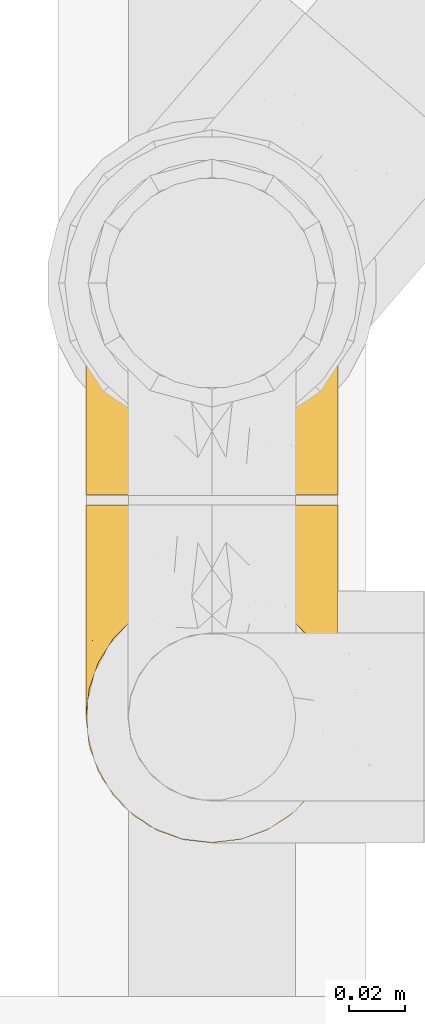
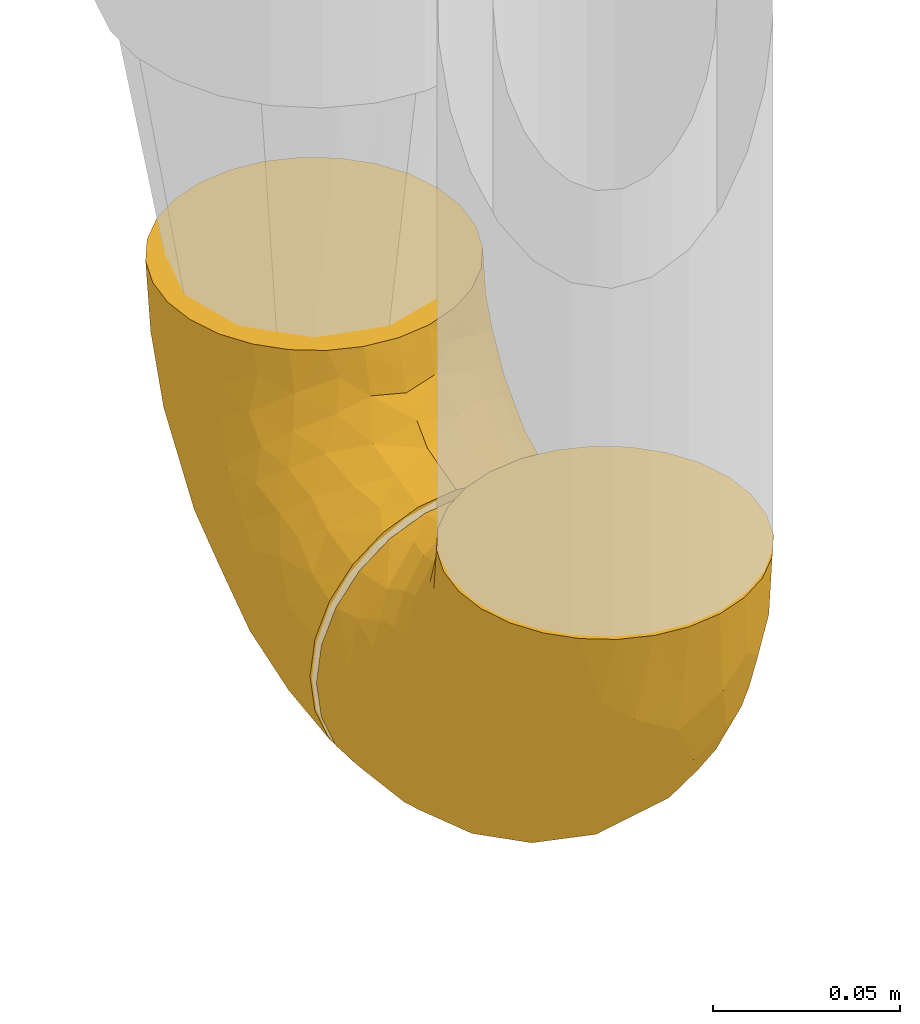
# One storey, part 193 of 827: 2 coverings.
"""IFC2X3 building model written with IfcOpenShell, lengths in millimetres."""

from ifc_helpers import new_model, entity, si_unit, converted_unit, derived_unit, direction, frame, origin, place, context, subcontext, project, spatial, faceted_brep, element, save


model = new_model("IFC2X3")

# Units and contexts
model_context = context("Model", 3, precision=0.01, world=origin(), true_north=direction((6.12303176911189e-17, 1.0)))
body_context = subcontext(model_context, "Body", "Model", "MODEL_VIEW")
ifc_project = project(units=[si_unit("LENGTHUNIT", "METRE", prefix="MILLI"), si_unit("AREAUNIT", "SQUARE_METRE"), si_unit("VOLUMEUNIT", "CUBIC_METRE"), converted_unit("PLANEANGLEUNIT", "DEGREE", entity("IfcRatioMeasure", 0.0174532925199433), si_unit("PLANEANGLEUNIT", "RADIAN"), dimensions=[0, 0, 0, 0, 0, 0, 0]), si_unit("MASSUNIT", "GRAM", prefix="KILO"), derived_unit("MASSDENSITYUNIT", [(si_unit("MASSUNIT", "GRAM", prefix="KILO"), 1), (si_unit("LENGTHUNIT", "METRE"), -3)]), derived_unit("MOMENTOFINERTIAUNIT", [(si_unit("LENGTHUNIT", "METRE"), 4)]), si_unit("TIMEUNIT", "SECOND"), si_unit("FREQUENCYUNIT", "HERTZ"), si_unit("THERMODYNAMICTEMPERATUREUNIT", "DEGREE_CELSIUS"), derived_unit("THERMALTRANSMITTANCEUNIT", [(si_unit("MASSUNIT", "GRAM", prefix="KILO"), 1), (si_unit("THERMODYNAMICTEMPERATUREUNIT", "KELVIN"), -1), (si_unit("TIMEUNIT", "SECOND"), -3)]), derived_unit("VOLUMETRICFLOWRATEUNIT", [(si_unit("LENGTHUNIT", "METRE"), 3), (si_unit("TIMEUNIT", "SECOND"), -1)]), derived_unit("MASSFLOWRATEUNIT", [(si_unit("MASSUNIT", "GRAM", prefix="KILO"), 1), (si_unit("TIMEUNIT", "SECOND"), -1)]), derived_unit("ROTATIONALFREQUENCYUNIT", [(si_unit("TIMEUNIT", "SECOND"), -1)]), si_unit("ELECTRICCURRENTUNIT", "AMPERE"), si_unit("ELECTRICVOLTAGEUNIT", "VOLT"), si_unit("POWERUNIT", "WATT"), si_unit("FORCEUNIT", "NEWTON", prefix="KILO"), si_unit("ILLUMINANCEUNIT", "LUX"), si_unit("LUMINOUSFLUXUNIT", "LUMEN"), si_unit("LUMINOUSINTENSITYUNIT", "CANDELA"), derived_unit("USERDEFINED", [(si_unit("MASSUNIT", "GRAM", prefix="KILO"), -1), (si_unit("LENGTHUNIT", "METRE"), -2), (si_unit("TIMEUNIT", "SECOND"), 3), (si_unit("LUMINOUSFLUXUNIT", "LUMEN"), 1)]), derived_unit("LINEARVELOCITYUNIT", [(si_unit("LENGTHUNIT", "METRE"), 1), (si_unit("TIMEUNIT", "SECOND"), -1)]), si_unit("PRESSUREUNIT", "PASCAL"), derived_unit("USERDEFINED", [(si_unit("LENGTHUNIT", "METRE"), -2), (si_unit("MASSUNIT", "GRAM", prefix="KILO"), 1), (si_unit("TIMEUNIT", "SECOND"), -2)]), derived_unit("LINEARFORCEUNIT", [(si_unit("MASSUNIT", "GRAM", prefix="KILO"), 1), (si_unit("LENGTHUNIT", "METRE"), 1), (si_unit("TIMEUNIT", "SECOND"), -2), (si_unit("LENGTHUNIT", "METRE"), -1)]), derived_unit("PLANARFORCEUNIT", [(si_unit("MASSUNIT", "GRAM", prefix="KILO"), 1), (si_unit("LENGTHUNIT", "METRE"), 1), (si_unit("TIMEUNIT", "SECOND"), -2), (si_unit("LENGTHUNIT", "METRE"), -2)])], contexts=[model_context])

# Site, building, storey
site_placement = place(None, origin())
site = spatial("IfcSite", under=ifc_project, at=site_placement, CompositionType="ELEMENT")
building_placement = place(site_placement, origin())
building = spatial("IfcBuilding", under=site, at=building_placement, CompositionType="ELEMENT")
storey_placement = place(building_placement, frame((0.0, 0.0, 28200.0)))
storey = spatial("IfcBuildingStorey", under=building, at=storey_placement, Name="08", CompositionType="ELEMENT", Elevation=28200.0)

# Coverings
covering_1_placement = place(storey_placement, frame((36582.9, 10004.0, 353.25)))
element("IfcCovering", 1, at=covering_1_placement, inside=storey, Name=":ADSK_", ObjectType=":ADSK_", PredefinedType="INSULATION", context=body_context, shape_type="Brep", body=[
    faceted_brep([(90.76, 87.65, 122.75), (87.42, 97.19, 122.75), (82.04, 105.75, 122.75), (74.89, 112.9, 122.75), (66.33, 118.28, 122.75), (56.79, 121.61, 122.75), (46.75, 122.75, 122.75), (36.69, 121.61, 122.75), (27.15, 118.27, 122.75), (18.59, 112.89, 122.75), (11.44, 105.74, 122.75), (6.06, 97.18, 122.75), (2.73, 87.64, 122.75), (1.6, 77.6, 122.75), (2.73, 67.54, 122.75), (6.07, 58.0, 122.75), (11.45, 49.44, 122.75), (18.6, 42.29, 122.75), (27.16, 36.91, 122.75), (36.7, 33.58, 122.75), (46.75, 32.45, 122.75), (56.8, 33.58, 122.75), (66.34, 36.92, 122.75), (74.9, 42.3, 122.75), (82.05, 49.45, 122.75), (87.43, 58.01, 122.75), (90.76, 67.55, 122.75), (91.9, 77.6, 122.75), (35.06, 1.6, 90.36), (24.17, 1.6, 85.85), (14.82, 1.6, 78.67), (7.64, 1.6, 69.32), (3.13, 1.6, 58.43), (1.6, 1.6, 46.75), (3.13, 1.6, 35.06), (7.64, 1.6, 24.17), (14.82, 1.6, 14.82), (24.17, 1.6, 7.64), (35.06, 1.6, 3.13), (46.75, 1.6, 1.6), (58.43, 1.6, 3.13), (69.32, 1.6, 7.64), (78.67, 1.6, 14.82), (85.85, 1.6, 24.17), (90.36, 1.6, 35.06), (91.9, 1.6, 46.75), (90.36, 1.6, 58.43), (85.85, 1.6, 69.32), (78.67, 1.6, 78.67), (69.32, 1.6, 85.85), (58.43, 1.6, 90.36), (46.75, 1.6, 91.9), (46.75, 99.61, 51.54), (55.2, 95.26, 47.17), (46.75, 86.21, 38.13), (46.75, 39.03, 7.52), (54.53, 30.75, 5.85), (46.75, 23.8, 5.11), (59.63, 60.8, 19.2), (62.07, 85.37, 38.98), (71.86, 73.64, 35.02), (62.65, 31.01, 8.21), (71.33, 49.14, 19.28), (72.93, 23.88, 12.19), (91.2, 82.74, 101.39), (86.31, 43.48, 34.43), (80.89, 29.47, 20.95), (79.49, 56.38, 30.74), (90.68, 72.18, 72.93), (86.84, 72.24, 56.64), (87.38, 87.6, 80.81), (76.87, 107.24, 93.43), (83.73, 101.1, 100.76), (81.03, 95.16, 74.27), (91.9, 71.81, 93.66), (91.9, 63.57, 81.33), (91.9, 55.34, 69.01), (91.03, 23.66, 40.87), (87.58, 20.55, 29.38), (56.52, 107.97, 67.05), (46.75, 116.82, 85.31), (60.4, 117.03, 93.68), (91.9, 30.68, 52.53), (91.9, 21.51, 50.71), (91.9, 12.33, 48.88), (67.87, 106.17, 72.77), (90.35, 52.37, 51.21), (69.57, 114.51, 101.18), (46.75, 119.23, 100.54), (79.91, 78.37, 48.74), (91.9, 75.46, 112.01), (91.9, 73.63, 102.83), (74.99, 101.51, 73.88), (46.75, 72.81, 24.73), (91.9, 43.01, 60.77), (88.53, 92.6, 103.08), (72.65, 91.86, 54.8), (46.75, 55.92, 16.13), (62.97, 99.01, 55.92), (46.75, 108.21, 68.42), (66.2, 32.05, 104.98), (56.6, 30.22, 108.58), (59.89, 23.37, 98.21), (90.95, 28.43, 61.56), (90.22, 16.44, 60.69), (76.64, 37.1, 100.0), (71.58, 28.88, 95.88), (79.99, 33.93, 90.81), (89.54, 50.17, 84.88), (89.97, 40.57, 73.29), (81.32, 47.62, 113.4), (74.56, 39.9, 109.8), (84.15, 47.92, 102.13), (90.37, 34.27, 67.29), (87.82, 24.65, 70.34), (90.98, 62.6, 95.15), (90.96, 66.18, 105.49), (85.14, 11.74, 71.5), (58.11, 13.89, 92.87), (46.75, 17.02, 96.03), (78.39, 15.86, 81.34), (88.22, 57.71, 107.44), (66.06, 9.11, 88.36), (68.6, 18.55, 90.43), (63.78, 34.74, 114.37), (88.42, 54.95, 98.41), (90.61, 57.35, 88.73), (83.8, 22.03, 76.89), (77.98, 24.8, 86.08), (91.22, 69.07, 112.64), (83.46, 42.31, 94.21), (46.75, 29.63, 112.22), (46.75, 28.31, 107.32), (84.66, 30.23, 79.95), (86.33, 40.13, 84.51), (46.75, 22.67, 101.67), (46.75, 12.12, 94.71), (15.1, 15.86, 81.34), (9.69, 22.03, 76.89), (15.52, 24.8, 86.08), (8.83, 30.23, 79.96), (35.39, 13.88, 92.87), (12.18, 47.61, 113.41), (1.6, 73.63, 102.83), (2.53, 66.17, 105.5), (2.27, 69.07, 112.64), (36.9, 30.22, 108.58), (27.31, 32.04, 104.98), (33.62, 23.36, 98.2), (5.07, 54.93, 98.4), (9.36, 47.91, 102.13), (5.27, 57.69, 107.44), (27.43, 9.1, 88.36), (1.6, 21.51, 50.71), (1.6, 12.33, 48.88), (10.05, 42.29, 94.22), (16.87, 37.09, 100.01), (8.35, 11.74, 71.5), (3.27, 16.44, 60.69), (1.6, 30.68, 52.53), (21.94, 28.86, 95.89), (29.72, 34.74, 114.37), (1.6, 63.57, 81.33), (1.6, 55.34, 69.01), (3.96, 50.17, 84.88), (1.6, 75.46, 112.01), (18.95, 39.89, 109.8), (2.54, 28.43, 61.56), (3.12, 34.27, 67.29), (1.6, 43.01, 60.77), (2.51, 62.59, 95.14), (3.52, 40.57, 73.29), (7.17, 40.13, 84.53), (1.6, 71.81, 93.66), (13.52, 33.92, 90.82), (2.88, 57.34, 88.73), (5.67, 24.65, 70.34), (24.89, 18.54, 90.43), (12.6, 29.47, 20.95), (7.18, 43.48, 34.43), (14.0, 56.4, 30.74), (22.16, 49.17, 19.29), (21.61, 73.69, 35.07), (3.14, 52.37, 51.21), (6.65, 72.26, 56.67), (20.82, 91.88, 54.85), (31.41, 85.36, 38.98), (5.91, 20.55, 29.38), (2.46, 23.66, 40.87), (33.87, 60.8, 19.2), (30.84, 31.02, 8.21), (38.96, 30.75, 5.85), (20.56, 23.9, 12.19), (2.81, 72.17, 72.93), (6.1, 87.59, 80.83), (2.29, 82.74, 101.39), (33.08, 117.03, 93.69), (16.61, 107.23, 93.43), (36.96, 107.97, 67.04), (9.75, 101.08, 100.76), (25.61, 106.17, 72.78), (30.5, 99.01, 55.93), (23.91, 114.5, 101.18), (12.45, 95.15, 74.27), (18.49, 101.5, 73.89), (4.96, 92.59, 103.09), (13.56, 78.38, 48.78), (38.28, 95.27, 47.19)], [[[0, 1, 2, 3, 4, 5, 6, 7, 8, 9, 10, 11, 12, 13, 14, 15, 16, 17, 18, 19, 20, 21, 22, 23, 24, 25, 26, 27]], [[28, 29, 30, 31, 32, 33, 34, 35, 36, 37, 38, 39, 40, 41, 42, 43, 44, 45, 46, 47, 48, 49, 50, 51]], [[52, 53, 54]], [[55, 56, 57]], [[58, 59, 60]], [[61, 62, 63]], [[27, 64, 0]], [[65, 66, 67]], [[41, 40, 61]], [[68, 69, 70]], [[66, 43, 42]], [[63, 42, 41]], [[71, 72, 73]], [[72, 2, 1]], [[68, 74, 75, 76]], [[45, 44, 77]], [[43, 78, 44]], [[79, 80, 81]], [[77, 82, 83, 84, 45]], [[79, 81, 85]], [[71, 2, 72]], [[65, 86, 77]], [[4, 81, 5]], [[66, 65, 78]], [[4, 3, 87]], [[81, 88, 5]], [[63, 66, 42]], [[68, 70, 64]], [[67, 60, 89]], [[71, 3, 2]], [[64, 27, 90, 91, 74]], [[92, 71, 73]], [[40, 57, 56]], [[59, 93, 54]], [[86, 76, 94, 82]], [[1, 0, 95]], [[58, 62, 61]], [[60, 96, 89]], [[85, 81, 87]], [[56, 97, 58]], [[65, 67, 69]], [[87, 81, 4]], [[67, 89, 69]], [[61, 63, 41]], [[95, 72, 1]], [[73, 72, 70]], [[69, 73, 70]], [[73, 89, 96]], [[3, 71, 87]], [[85, 87, 71]], [[58, 61, 56]], [[59, 58, 93]], [[76, 86, 68]], [[69, 89, 73]], [[68, 86, 69]], [[65, 69, 86]], [[68, 64, 74]], [[95, 64, 70]], [[98, 79, 85]], [[79, 52, 99, 80]], [[66, 62, 67]], [[62, 58, 60]], [[62, 60, 67]], [[59, 98, 96]], [[59, 96, 60]], [[96, 85, 92]], [[88, 81, 80]], [[88, 6, 5]], [[66, 63, 62]], [[64, 95, 0]], [[72, 95, 70]], [[77, 44, 78]], [[86, 82, 77]], [[40, 39, 57]], [[96, 98, 85]], [[40, 56, 61]], [[66, 78, 43]], [[77, 78, 65]], [[79, 98, 53]], [[96, 92, 73]], [[85, 71, 92]], [[97, 56, 55]], [[97, 93, 58]], [[53, 98, 59]], [[54, 53, 59]], [[79, 53, 52]], [[100, 101, 102]], [[46, 45, 84, 83]], [[103, 104, 82]], [[82, 104, 83]], [[105, 106, 107]], [[108, 109, 76]], [[110, 111, 112]], [[103, 113, 114]], [[115, 74, 116]], [[48, 47, 117]], [[118, 102, 119]], [[49, 48, 120]], [[74, 91, 116]], [[116, 121, 115]], [[49, 122, 50]], [[123, 106, 102]], [[124, 111, 22]], [[125, 126, 115]], [[23, 22, 111]], [[24, 110, 121]], [[120, 127, 128]], [[90, 26, 129]], [[27, 26, 90]], [[121, 125, 115]], [[24, 121, 25]], [[130, 105, 107]], [[129, 25, 116]], [[21, 20, 131]], [[120, 123, 122]], [[112, 105, 130]], [[50, 118, 51]], [[21, 124, 22]], [[101, 131, 132]], [[117, 120, 48]], [[24, 23, 110]], [[127, 114, 133]], [[75, 108, 76]], [[107, 134, 130]], [[133, 114, 113]], [[129, 116, 91]], [[25, 121, 116]], [[121, 112, 125]], [[75, 74, 115]], [[101, 135, 102]], [[131, 101, 21]], [[101, 100, 124]], [[128, 127, 133]], [[119, 136, 51, 118]], [[104, 47, 46]], [[83, 104, 46]], [[117, 104, 114]], [[101, 124, 21]], [[111, 124, 100]], [[102, 118, 123]], [[133, 134, 107]], [[111, 110, 23]], [[114, 104, 103]], [[94, 76, 109]], [[121, 110, 112]], [[122, 118, 50]], [[134, 109, 108]], [[133, 107, 128]], [[112, 108, 125]], [[126, 125, 108]], [[108, 75, 126]], [[75, 115, 126]], [[109, 134, 133]], [[130, 108, 112]], [[108, 130, 134]], [[105, 112, 111]], [[111, 100, 105]], [[106, 105, 100]], [[102, 106, 100]], [[128, 106, 123]], [[90, 129, 91]], [[25, 129, 26]], [[104, 117, 47]], [[117, 114, 127]], [[82, 94, 103]], [[113, 94, 109]], [[94, 113, 103]], [[133, 113, 109]], [[106, 128, 107]], [[123, 120, 128]], [[120, 122, 49]], [[118, 122, 123]], [[135, 101, 132]], [[135, 119, 102]], [[117, 127, 120]], [[30, 29, 137]], [[138, 139, 140]], [[51, 136, 119, 141]], [[142, 17, 16]], [[143, 144, 145]], [[146, 147, 148]], [[149, 150, 151]], [[152, 29, 28]], [[33, 32, 153, 154]], [[150, 155, 156]], [[157, 31, 30]], [[153, 158, 159]], [[29, 152, 137]], [[148, 141, 119]], [[156, 160, 147]], [[148, 135, 146]], [[137, 138, 157]], [[19, 161, 146]], [[162, 163, 164]], [[14, 13, 165]], [[153, 32, 158]], [[147, 161, 166]], [[18, 17, 166]], [[167, 168, 169]], [[166, 150, 156]], [[151, 150, 142]], [[151, 170, 149]], [[151, 16, 15]], [[171, 140, 172]], [[165, 143, 145]], [[173, 170, 144]], [[142, 166, 17]], [[19, 131, 20]], [[144, 170, 151]], [[18, 161, 19]], [[173, 144, 143]], [[140, 139, 174]], [[171, 164, 163]], [[164, 172, 155]], [[151, 15, 144]], [[145, 15, 14]], [[173, 162, 170]], [[149, 175, 164]], [[19, 146, 131]], [[132, 131, 146]], [[160, 148, 147]], [[159, 158, 167]], [[135, 132, 146]], [[158, 32, 31]], [[157, 158, 31]], [[167, 158, 176]], [[166, 161, 18]], [[146, 161, 147]], [[148, 177, 141]], [[171, 168, 140]], [[171, 163, 169]], [[151, 142, 16]], [[166, 142, 150]], [[152, 141, 177]], [[51, 141, 28]], [[138, 140, 176]], [[172, 140, 174]], [[175, 149, 170]], [[164, 150, 149]], [[170, 162, 175]], [[162, 164, 175]], [[155, 172, 174]], [[171, 172, 164]], [[155, 174, 156]], [[164, 155, 150]], [[160, 156, 174]], [[147, 166, 156]], [[139, 160, 174]], [[148, 160, 177]], [[15, 145, 144]], [[165, 145, 14]], [[137, 157, 30]], [[158, 157, 176]], [[168, 167, 176]], [[169, 159, 167]], [[140, 168, 176]], [[169, 168, 171]], [[137, 177, 139]], [[160, 139, 177]], [[141, 152, 28]], [[137, 152, 177]], [[148, 119, 135]], [[157, 138, 176]], [[139, 138, 137]], [[178, 179, 180]], [[181, 180, 182]], [[179, 183, 184]], [[185, 186, 182]], [[187, 188, 179]], [[188, 33, 154, 153, 159]], [[181, 189, 190]], [[35, 34, 187]], [[191, 38, 190]], [[192, 178, 181]], [[179, 184, 180]], [[192, 190, 37]], [[37, 190, 38]], [[36, 35, 178]], [[54, 93, 186]], [[35, 187, 178]], [[193, 194, 184]], [[195, 173, 143, 165, 13]], [[195, 193, 173]], [[193, 163, 162, 173]], [[13, 12, 195]], [[8, 7, 196]], [[9, 197, 10]], [[198, 80, 99, 52]], [[196, 7, 88]], [[197, 199, 10]], [[182, 189, 181]], [[200, 198, 201]], [[200, 196, 198]], [[9, 8, 202]], [[194, 199, 203]], [[192, 37, 36]], [[80, 196, 88]], [[183, 159, 169, 163]], [[188, 34, 33]], [[202, 200, 197]], [[185, 203, 204]], [[202, 8, 196]], [[10, 199, 11]], [[12, 11, 205]], [[38, 191, 57]], [[189, 97, 191]], [[203, 199, 197]], [[205, 199, 194]], [[204, 203, 197]], [[184, 203, 206]], [[200, 202, 196]], [[197, 9, 202]], [[207, 54, 186]], [[97, 55, 191]], [[194, 203, 184]], [[183, 163, 193]], [[184, 206, 180]], [[183, 193, 184]], [[205, 195, 12]], [[193, 195, 194]], [[80, 198, 196]], [[207, 186, 201]], [[182, 180, 206]], [[181, 178, 180]], [[185, 182, 206]], [[182, 186, 189]], [[203, 185, 206]], [[185, 200, 201]], [[7, 6, 88]], [[178, 192, 36]], [[190, 192, 181]], [[199, 205, 11]], [[195, 205, 194]], [[159, 183, 188]], [[179, 188, 183]], [[57, 191, 55]], [[57, 39, 38]], [[189, 191, 190]], [[188, 187, 34]], [[178, 187, 179]], [[186, 93, 189]], [[197, 200, 204]], [[185, 204, 200]], [[189, 93, 97]], [[207, 198, 52]], [[185, 201, 186]], [[198, 207, 201]], [[54, 207, 52]]]),
])
covering_2_placement = place(storey_placement, frame((36582.9, 9879.43, 353.25)))
element("IfcCovering", 2, at=covering_2_placement, inside=storey, Name=":ADSK_", ObjectType=":ADSK_", PredefinedType="INSULATION", context=body_context, shape_type="Brep", body=[
    faceted_brep([(2.73, 36.69, 122.75), (6.07, 27.15, 122.75), (11.45, 18.59, 122.75), (18.6, 11.44, 122.75), (27.16, 6.06, 122.75), (36.7, 2.73, 122.75), (46.75, 1.6, 122.75), (56.8, 2.73, 122.75), (66.34, 6.07, 122.75), (74.9, 11.45, 122.75), (82.05, 18.6, 122.75), (87.43, 27.16, 122.75), (90.76, 36.7, 122.75), (91.9, 46.75, 122.75), (90.76, 56.8, 122.75), (87.42, 66.34, 122.75), (82.04, 74.9, 122.75), (74.89, 82.05, 122.75), (66.33, 87.43, 122.75), (56.79, 90.76, 122.75), (46.75, 91.9, 122.75), (36.69, 90.76, 122.75), (27.15, 87.42, 122.75), (18.59, 82.04, 122.75), (11.44, 74.89, 122.75), (6.06, 66.33, 122.75), (2.73, 56.79, 122.75), (1.6, 46.75, 122.75), (58.43, 122.75, 90.36), (69.32, 122.75, 85.85), (78.67, 122.75, 78.67), (85.85, 122.75, 69.32), (90.36, 122.75, 58.43), (91.9, 122.75, 46.75), (90.36, 122.75, 35.06), (85.85, 122.75, 24.17), (78.67, 122.75, 14.82), (69.32, 122.75, 7.64), (58.43, 122.75, 3.13), (46.75, 122.75, 1.6), (35.06, 122.75, 3.13), (24.17, 122.75, 7.64), (14.82, 122.75, 14.82), (7.64, 122.75, 24.17), (3.13, 122.75, 35.06), (1.6, 122.75, 46.75), (3.13, 122.75, 58.43), (7.64, 122.75, 69.32), (14.82, 122.75, 78.67), (24.17, 122.75, 85.85), (35.06, 122.75, 90.36), (46.75, 122.75, 91.9), (46.75, 24.73, 51.54), (38.29, 29.08, 47.17), (46.75, 38.13, 38.13), (46.75, 85.31, 7.52), (38.96, 93.59, 5.85), (46.75, 100.54, 5.11), (33.86, 63.54, 19.2), (31.42, 38.98, 38.98), (21.63, 50.71, 35.02), (30.84, 93.33, 8.21), (22.16, 75.2, 19.28), (20.56, 100.46, 12.19), (2.29, 41.6, 101.39), (7.18, 80.86, 34.43), (12.6, 94.87, 20.95), (14.0, 67.96, 30.74), (2.81, 52.16, 72.93), (6.65, 52.1, 56.64), (6.11, 36.74, 80.81), (16.62, 17.11, 93.43), (9.76, 23.24, 100.76), (12.46, 29.18, 74.27), (1.6, 52.53, 93.66), (1.6, 60.77, 81.33), (1.6, 69.01, 69.01), (2.46, 100.68, 40.87), (5.91, 103.79, 29.38), (36.97, 16.37, 67.05), (46.75, 7.52, 85.31), (33.09, 7.31, 93.68), (1.6, 93.66, 52.53), (1.6, 102.83, 50.71), (1.6, 112.01, 48.88), (25.62, 18.17, 72.77), (3.14, 71.97, 51.21), (23.92, 9.83, 101.18), (46.75, 5.11, 100.54), (13.58, 45.97, 48.74), (1.6, 48.88, 112.01), (1.6, 50.71, 102.83), (18.5, 22.83, 73.88), (46.75, 51.54, 24.73), (1.6, 81.33, 60.77), (4.96, 31.74, 103.08), (20.84, 32.48, 54.8), (46.75, 68.42, 16.13), (30.52, 25.33, 55.92), (46.75, 16.13, 68.42), (27.29, 92.29, 104.98), (36.89, 94.12, 108.58), (33.6, 100.97, 98.21), (2.54, 95.91, 61.56), (3.27, 107.9, 60.69), (16.85, 87.24, 100.0), (21.91, 95.46, 95.88), (13.5, 90.41, 90.81), (3.96, 74.17, 84.88), (3.52, 83.77, 73.29), (12.17, 76.72, 113.4), (18.93, 84.44, 109.8), (9.34, 76.42, 102.13), (3.12, 90.07, 67.29), (5.67, 99.69, 70.34), (2.51, 61.74, 95.15), (2.53, 58.16, 105.49), (8.35, 112.6, 71.5), (35.39, 110.45, 92.87), (46.75, 107.32, 96.03), (15.1, 108.48, 81.34), (5.27, 66.63, 107.44), (27.43, 115.23, 88.36), (24.89, 105.79, 90.43), (29.71, 89.6, 114.37), (5.07, 69.39, 98.41), (2.88, 66.99, 88.73), (9.69, 102.31, 76.89), (15.51, 99.54, 86.08), (2.27, 55.27, 112.64), (10.03, 82.03, 94.21), (46.75, 94.71, 112.22), (46.75, 96.03, 107.32), (8.83, 94.11, 79.95), (7.16, 84.21, 84.51), (46.75, 101.67, 101.67), (46.75, 112.22, 94.71), (78.39, 108.48, 81.34), (83.8, 102.31, 76.89), (77.97, 99.54, 86.08), (84.66, 94.11, 79.96), (58.1, 110.46, 92.87), (81.31, 76.74, 113.41), (91.9, 50.71, 102.83), (90.96, 58.17, 105.5), (91.22, 55.27, 112.64), (56.59, 94.12, 108.58), (66.18, 92.3, 104.98), (59.87, 100.98, 98.2), (88.42, 69.41, 98.4), (84.13, 76.44, 102.13), (88.22, 66.65, 107.44), (66.06, 115.24, 88.36), (91.9, 102.83, 50.71), (91.9, 112.01, 48.88), (83.44, 82.05, 94.22), (76.62, 87.25, 100.01), (85.14, 112.6, 71.5), (90.22, 107.9, 60.69), (91.9, 93.66, 52.53), (71.55, 95.48, 95.89), (63.77, 89.6, 114.37), (91.9, 60.77, 81.33), (91.9, 69.01, 69.01), (89.53, 74.17, 84.88), (91.9, 48.88, 112.01), (74.55, 84.45, 109.8), (90.95, 95.91, 61.56), (90.37, 90.07, 67.29), (91.9, 81.33, 60.77), (90.98, 61.75, 95.14), (89.97, 83.77, 73.29), (86.32, 84.21, 84.53), (91.9, 52.53, 93.66), (79.97, 90.42, 90.82), (90.61, 67.0, 88.73), (87.82, 99.69, 70.34), (68.6, 105.8, 90.43), (80.89, 94.87, 20.95), (86.31, 80.86, 34.43), (79.49, 67.95, 30.74), (71.33, 75.17, 19.29), (71.88, 50.65, 35.07), (90.35, 71.97, 51.21), (86.85, 52.08, 56.67), (72.67, 32.46, 54.85), (62.08, 38.98, 38.98), (87.58, 103.79, 29.38), (91.03, 100.68, 40.87), (59.62, 63.54, 19.2), (62.65, 93.32, 8.21), (54.53, 93.59, 5.85), (72.93, 100.44, 12.19), (90.68, 52.17, 72.93), (87.39, 36.75, 80.83), (91.2, 41.61, 101.39), (60.41, 7.31, 93.69), (76.88, 17.12, 93.43), (56.53, 16.37, 67.04), (83.74, 23.26, 100.76), (67.88, 18.17, 72.78), (62.99, 25.33, 55.93), (69.58, 9.84, 101.18), (81.04, 29.19, 74.27), (75.0, 22.84, 73.89), (88.53, 31.75, 103.09), (79.93, 45.96, 48.78), (55.21, 29.07, 47.19)], [[[0, 1, 2, 3, 4, 5, 6, 7, 8, 9, 10, 11, 12, 13, 14, 15, 16, 17, 18, 19, 20, 21, 22, 23, 24, 25, 26, 27]], [[28, 29, 30, 31, 32, 33, 34, 35, 36, 37, 38, 39, 40, 41, 42, 43, 44, 45, 46, 47, 48, 49, 50, 51]], [[52, 53, 54]], [[55, 56, 57]], [[58, 59, 60]], [[61, 62, 63]], [[27, 64, 0]], [[65, 66, 67]], [[41, 40, 61]], [[68, 69, 70]], [[66, 43, 42]], [[63, 42, 41]], [[71, 72, 73]], [[72, 2, 1]], [[68, 74, 75, 76]], [[45, 44, 77]], [[43, 78, 44]], [[79, 80, 81]], [[77, 82, 83, 84, 45]], [[79, 81, 85]], [[71, 2, 72]], [[65, 86, 77]], [[4, 81, 5]], [[66, 65, 78]], [[4, 3, 87]], [[81, 88, 5]], [[63, 66, 42]], [[68, 70, 64]], [[67, 60, 89]], [[71, 3, 2]], [[64, 27, 90, 91, 74]], [[92, 71, 73]], [[40, 57, 56]], [[59, 93, 54]], [[86, 76, 94, 82]], [[1, 0, 95]], [[58, 62, 61]], [[60, 96, 89]], [[85, 81, 87]], [[56, 97, 58]], [[65, 67, 69]], [[87, 81, 4]], [[67, 89, 69]], [[61, 63, 41]], [[95, 72, 1]], [[73, 72, 70]], [[69, 73, 70]], [[73, 89, 96]], [[3, 71, 87]], [[85, 87, 71]], [[58, 61, 56]], [[59, 58, 93]], [[76, 86, 68]], [[69, 89, 73]], [[68, 86, 69]], [[65, 69, 86]], [[68, 64, 74]], [[95, 64, 70]], [[98, 79, 85]], [[79, 52, 99, 80]], [[66, 62, 67]], [[62, 58, 60]], [[62, 60, 67]], [[59, 98, 96]], [[59, 96, 60]], [[96, 85, 92]], [[88, 81, 80]], [[88, 6, 5]], [[66, 63, 62]], [[64, 95, 0]], [[72, 95, 70]], [[77, 44, 78]], [[86, 82, 77]], [[40, 39, 57]], [[96, 98, 85]], [[40, 56, 61]], [[66, 78, 43]], [[77, 78, 65]], [[79, 98, 53]], [[96, 92, 73]], [[85, 71, 92]], [[97, 56, 55]], [[97, 93, 58]], [[53, 98, 59]], [[54, 53, 59]], [[79, 53, 52]], [[100, 101, 102]], [[46, 45, 84, 83]], [[103, 104, 82]], [[82, 104, 83]], [[105, 106, 107]], [[108, 109, 76]], [[110, 111, 112]], [[103, 113, 114]], [[115, 74, 116]], [[48, 47, 117]], [[118, 102, 119]], [[49, 48, 120]], [[74, 91, 116]], [[116, 121, 115]], [[49, 122, 50]], [[123, 106, 102]], [[124, 111, 22]], [[125, 126, 115]], [[23, 22, 111]], [[24, 110, 121]], [[120, 127, 128]], [[90, 26, 129]], [[27, 26, 90]], [[121, 125, 115]], [[24, 121, 25]], [[130, 105, 107]], [[129, 25, 116]], [[21, 20, 131]], [[120, 123, 122]], [[112, 105, 130]], [[50, 118, 51]], [[21, 124, 22]], [[101, 131, 132]], [[117, 120, 48]], [[24, 23, 110]], [[127, 114, 133]], [[75, 108, 76]], [[107, 134, 130]], [[133, 114, 113]], [[129, 116, 91]], [[25, 121, 116]], [[121, 112, 125]], [[75, 74, 115]], [[101, 135, 102]], [[131, 101, 21]], [[101, 100, 124]], [[128, 127, 133]], [[119, 136, 51, 118]], [[104, 47, 46]], [[83, 104, 46]], [[117, 104, 114]], [[101, 124, 21]], [[111, 124, 100]], [[102, 118, 123]], [[133, 134, 107]], [[111, 110, 23]], [[114, 104, 103]], [[94, 76, 109]], [[121, 110, 112]], [[122, 118, 50]], [[134, 109, 108]], [[133, 107, 128]], [[112, 108, 125]], [[126, 125, 108]], [[108, 75, 126]], [[75, 115, 126]], [[109, 134, 133]], [[130, 108, 112]], [[108, 130, 134]], [[105, 112, 111]], [[111, 100, 105]], [[106, 105, 100]], [[102, 106, 100]], [[128, 106, 123]], [[90, 129, 91]], [[25, 129, 26]], [[104, 117, 47]], [[117, 114, 127]], [[82, 94, 103]], [[113, 94, 109]], [[94, 113, 103]], [[133, 113, 109]], [[106, 128, 107]], [[123, 120, 128]], [[120, 122, 49]], [[118, 122, 123]], [[135, 101, 132]], [[135, 119, 102]], [[117, 127, 120]], [[30, 29, 137]], [[138, 139, 140]], [[51, 136, 119, 141]], [[142, 17, 16]], [[143, 144, 145]], [[146, 147, 148]], [[149, 150, 151]], [[152, 29, 28]], [[33, 32, 153, 154]], [[150, 155, 156]], [[157, 31, 30]], [[153, 158, 159]], [[29, 152, 137]], [[148, 141, 119]], [[156, 160, 147]], [[148, 135, 146]], [[137, 138, 157]], [[19, 161, 146]], [[162, 163, 164]], [[14, 13, 165]], [[153, 32, 158]], [[147, 161, 166]], [[18, 17, 166]], [[167, 168, 169]], [[166, 150, 156]], [[151, 150, 142]], [[151, 170, 149]], [[151, 16, 15]], [[171, 140, 172]], [[165, 143, 145]], [[173, 170, 144]], [[142, 166, 17]], [[19, 131, 20]], [[144, 170, 151]], [[18, 161, 19]], [[173, 144, 143]], [[140, 139, 174]], [[171, 164, 163]], [[164, 172, 155]], [[151, 15, 144]], [[145, 15, 14]], [[173, 162, 170]], [[149, 175, 164]], [[19, 146, 131]], [[132, 131, 146]], [[160, 148, 147]], [[159, 158, 167]], [[135, 132, 146]], [[158, 32, 31]], [[157, 158, 31]], [[167, 158, 176]], [[166, 161, 18]], [[146, 161, 147]], [[148, 177, 141]], [[171, 168, 140]], [[171, 163, 169]], [[151, 142, 16]], [[166, 142, 150]], [[152, 141, 177]], [[51, 141, 28]], [[138, 140, 176]], [[172, 140, 174]], [[175, 149, 170]], [[164, 150, 149]], [[170, 162, 175]], [[162, 164, 175]], [[155, 172, 174]], [[171, 172, 164]], [[155, 174, 156]], [[164, 155, 150]], [[160, 156, 174]], [[147, 166, 156]], [[139, 160, 174]], [[148, 160, 177]], [[15, 145, 144]], [[165, 145, 14]], [[137, 157, 30]], [[158, 157, 176]], [[168, 167, 176]], [[169, 159, 167]], [[140, 168, 176]], [[169, 168, 171]], [[137, 177, 139]], [[160, 139, 177]], [[141, 152, 28]], [[137, 152, 177]], [[148, 119, 135]], [[157, 138, 176]], [[139, 138, 137]], [[178, 179, 180]], [[181, 180, 182]], [[179, 183, 184]], [[185, 186, 182]], [[187, 188, 179]], [[188, 33, 154, 153, 159]], [[181, 189, 190]], [[35, 34, 187]], [[191, 38, 190]], [[192, 178, 181]], [[179, 184, 180]], [[192, 190, 37]], [[37, 190, 38]], [[36, 35, 178]], [[54, 93, 186]], [[35, 187, 178]], [[193, 194, 184]], [[195, 173, 143, 165, 13]], [[195, 193, 173]], [[193, 163, 162, 173]], [[13, 12, 195]], [[8, 7, 196]], [[9, 197, 10]], [[198, 80, 99, 52]], [[196, 7, 88]], [[197, 199, 10]], [[182, 189, 181]], [[200, 198, 201]], [[200, 196, 198]], [[9, 8, 202]], [[194, 199, 203]], [[192, 37, 36]], [[80, 196, 88]], [[183, 159, 169, 163]], [[188, 34, 33]], [[202, 200, 197]], [[185, 203, 204]], [[202, 8, 196]], [[10, 199, 11]], [[12, 11, 205]], [[38, 191, 57]], [[189, 97, 191]], [[203, 199, 197]], [[205, 199, 194]], [[204, 203, 197]], [[184, 203, 206]], [[200, 202, 196]], [[197, 9, 202]], [[207, 54, 186]], [[97, 55, 191]], [[194, 203, 184]], [[183, 163, 193]], [[184, 206, 180]], [[183, 193, 184]], [[205, 195, 12]], [[193, 195, 194]], [[80, 198, 196]], [[207, 186, 201]], [[182, 180, 206]], [[181, 178, 180]], [[185, 182, 206]], [[182, 186, 189]], [[203, 185, 206]], [[185, 200, 201]], [[7, 6, 88]], [[178, 192, 36]], [[190, 192, 181]], [[199, 205, 11]], [[195, 205, 194]], [[159, 183, 188]], [[179, 188, 183]], [[57, 191, 55]], [[57, 39, 38]], [[189, 191, 190]], [[188, 187, 34]], [[178, 187, 179]], [[186, 93, 189]], [[197, 200, 204]], [[185, 204, 200]], [[189, 93, 97]], [[207, 198, 52]], [[185, 201, 186]], [[198, 207, 201]], [[54, 207, 52]]]),
])

save(model, "model.ifc")
